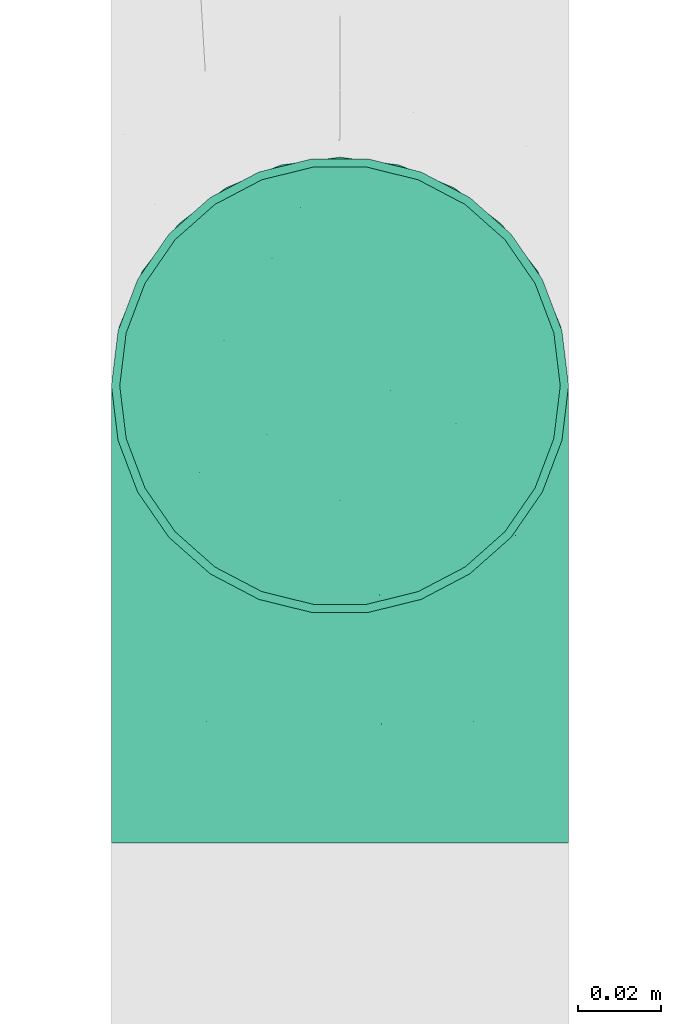
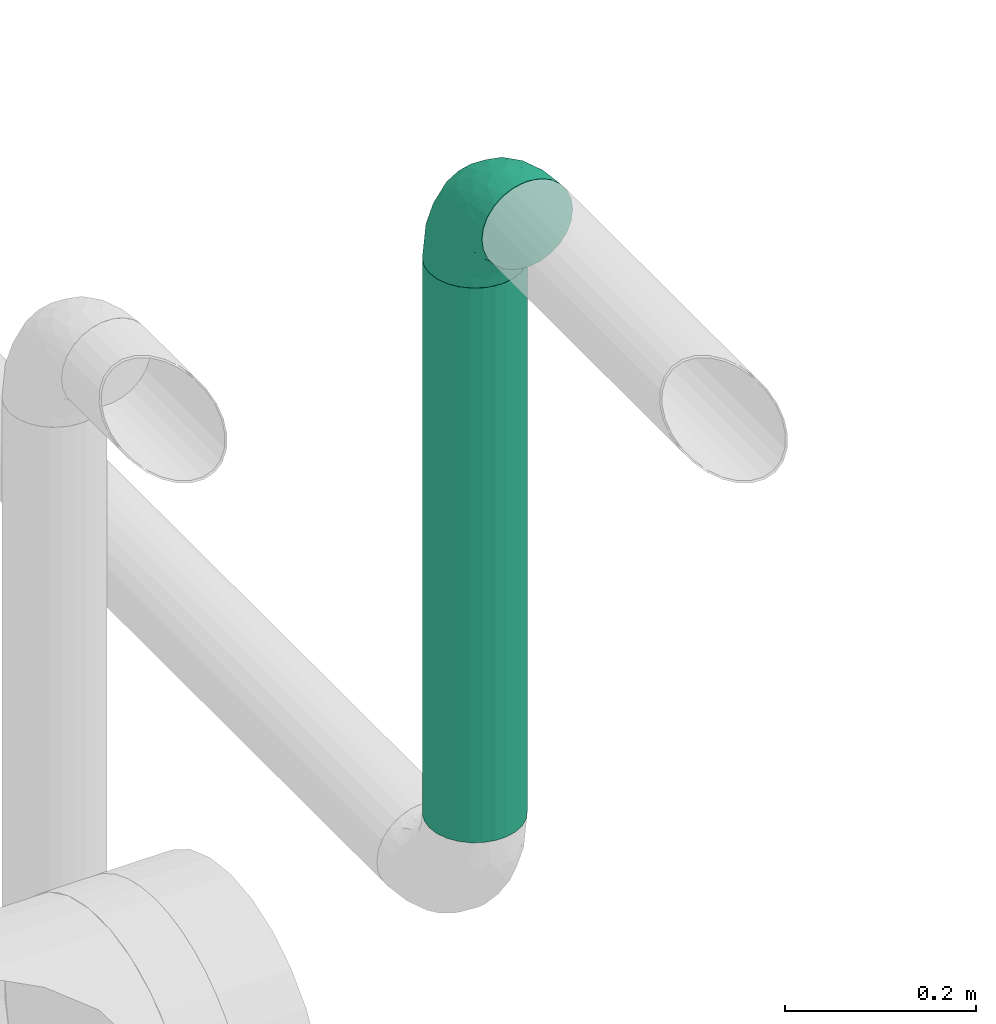
# One storey, part 77 of 91: 1 flow fitting, 1 flow segment.
"""IFC2X3 building model written with IfcOpenShell, lengths in millimetres."""

from ifc_helpers import new_model, entity, si_unit, converted_unit, derived_unit, direction, frame, origin_with_axes, origin_2d_with_axis, place, context, subcontext, project, spatial, hollow_circle, extrude, open_shell, surface_model, source, transform, mapped, material, layer, layer_set, layer_usage, type_object, element, save


model = new_model("IFC2X3")

# Units and contexts
model_context = context("Model", 3, precision=1e-05, world=origin_with_axes(), true_north=direction((0.0, 1.0)))
body_context = subcontext(model_context, "Body", "Model", "MODEL_VIEW")
ifc_project = project(units=[si_unit("AREAUNIT", "SQUARE_METRE"), si_unit("VOLUMEUNIT", "CUBIC_METRE", prefix="DECI"), si_unit("TIMEUNIT", "SECOND"), si_unit("THERMODYNAMICTEMPERATUREUNIT", "DEGREE_CELSIUS"), si_unit("PRESSUREUNIT", "PASCAL"), si_unit("MASSUNIT", "GRAM", prefix="KILO"), si_unit("LENGTHUNIT", "METRE", prefix="MILLI"), si_unit("POWERUNIT", "WATT"), si_unit("ELECTRICCURRENTUNIT", "AMPERE"), si_unit("ELECTRICVOLTAGEUNIT", "VOLT"), derived_unit("VOLUMETRICFLOWRATEUNIT", [(si_unit("VOLUMEUNIT", "CUBIC_METRE", prefix="DECI"), 1), (si_unit("TIMEUNIT", "SECOND"), -1)]), derived_unit("LINEARVELOCITYUNIT", [(si_unit("LENGTHUNIT", "METRE"), 1), (si_unit("TIMEUNIT", "SECOND"), -1)]), derived_unit("MASSDENSITYUNIT", [(si_unit("MASSUNIT", "GRAM", prefix="KILO"), 1), (si_unit("VOLUMEUNIT", "CUBIC_METRE"), -1)]), converted_unit("PLANEANGLEUNIT", "DEGREE", entity("IfcRatioMeasure", 0.01745), si_unit("PLANEANGLEUNIT", "RADIAN"), dimensions=[0, 0, 0, 0, 0, 0, 0])], contexts=[model_context])

# Site, building, storey
site_placement = place(None, origin_with_axes())
site = spatial("IfcSite", under=ifc_project, at=site_placement, CompositionType="ELEMENT")
building_placement = place(site_placement, origin_with_axes())
building = spatial("IfcBuilding", under=site, at=building_placement, Name="mc-building", CompositionType="ELEMENT")
storey_placement = place(building_placement, frame((0.0, 0.0, 8700.0), z_axis=(0.0, 0.0, 1.0), x_axis=(1.0, 0.0, 0.0)))
storey = spatial("IfcBuildingStorey", under=building, at=storey_placement, CompositionType="ELEMENT", Elevation=8700.0)

# Flow segment
ifc_material = material(Name="FZ1")
ifc_layer = layer(ifc_material, 0.0)
ifc_layer_set = layer_set([ifc_layer], Name="FZ1")
ifc_layer_usage = layer_usage(ifc_layer_set, "AXIS1", "POSITIVE", 0.0)
duct_segment_type = type_object("IfcDuctSegmentType", PredefinedType="RIGIDSEGMENT")
shared_shape_1 = source(origin_with_axes(), body_context, "Body", "SweptSolid", [
    extrude(hollow_circle(Radius=55.0, WallThickness=2.0, at=origin_2d_with_axis()), frame((0.0, 0.0, 0.0), z_axis=(1.0, 0.0, 0.0), x_axis=(0.0, 1.0, 0.0)), (0.0, 0.0, 1.0), 709.0),
])
flow_segment_placement = place(storey_placement, frame((26911.82755, 11040.50687, 1234.0), z_axis=(0.0, 1.0, 0.0), x_axis=(0.0, 0.0, -1.0)))
element("IfcFlowSegment", 1, at=flow_segment_placement, inside=storey, type_object=duct_segment_type, material=ifc_layer_usage, context=body_context, shape_type="MappedRepresentation", body=[
    mapped(shared_shape_1, transform((0.0, 0.0, 0.0), scale=1.0)),
])

# Flow fitting
duct_fitting_type = type_object("IfcDuctFittingType", Name="BU", PredefinedType="BEND")
shared_shape_2 = source(origin_with_axes(), body_context, "Body", "SurfaceModel", [
    surface_model("IfcShellBasedSurfaceModel", [(-110.0, 0.0, -55.0), (-110.0, -14.23505, -53.12592), (-110.0, 14.23505, -53.12592), (-110.0, 53.12592, 14.23505), (-110.0, 27.5, -47.63139), (-110.0, 38.89087, -38.89087), (-110.0, -55.0, 0.0), (-110.0, -53.12592, 14.23505), (-110.0, -38.89087, -38.89087), (-110.0, -27.5, -47.63139), (-110.0, -53.12592, -14.23505), (-110.0, -47.63139, -27.5), (-110.0, -14.23505, 53.12592), (-110.0, 14.23505, 53.12592), (-110.0, 27.5, 47.63139), (-110.0, -47.63139, 27.5), (-110.0, -38.89087, 38.89087), (-110.0, -27.5, 47.63139), (-110.0, 0.0, 55.0), (-110.0, 55.0, 0.0), (-110.0, 53.12592, -14.23505), (-110.0, 47.63139, -27.5), (-110.0, 47.63139, 27.5), (-110.0, 38.89087, 38.89087), (-14.23505, 110.0, -53.12592), (-55.0, 110.0, 0.0), (0.0, 110.0, -55.0), (-27.5, 110.0, -47.63139), (-38.89087, 110.0, -38.89087), (-47.63139, 110.0, -27.5), (38.89087, 110.0, -38.89087), (53.12592, 110.0, 14.23505), (27.5, 110.0, -47.63139), (14.23505, 110.0, -53.12592), (47.63139, 110.0, -27.5), (53.12592, 110.0, -14.23505), (55.0, 110.0, 0.0), (-53.12592, 110.0, -14.23505), (-53.12592, 110.0, 14.23505), (-47.63139, 110.0, 27.5), (-38.89087, 110.0, 38.89087), (-27.5, 110.0, 47.63139), (0.0, 110.0, 55.0), (-14.23505, 110.0, 53.12592), (38.89087, 110.0, 38.89087), (47.63139, 110.0, 27.5), (27.5, 110.0, 47.63139), (14.23505, 110.0, 53.12592), (-64.21732, 48.68956, 43.63444), (-76.6405, 38.18013, 45.55988), (-60.44912, 32.56953, 51.94617), (-76.00813, 5.38378, 55.0), (-90.15553, 11.94394, 54.09138), (-78.5998, 26.77405, 50.81338), (-70.18771, 18.55163, 54.03432), (-75.55424, 54.2118, 32.41257), (-93.27622, 45.77614, 33.48188), (-96.12334, 22.13664, 50.81337), (-21.00813, 45.34362, 55.0), (-18.36258, 70.48427, 54.04484), (-32.04182, 59.64019, 52.24446), (-63.88653, 74.77858, 17.99134), (-74.66383, 63.08407, 19.92123), (-63.60674, 66.07878, 29.97482), (-99.597, 52.72185, 18.52927), (-93.11138, 56.59448, 10.50359), (-98.21577, 57.34403, 0.0), (-53.42855, 92.60092, 21.04759), (-88.54852, 54.8376, 21.04759), (-11.86161, 90.23965, 54.10313), (-5.38378, 76.00813, 55.0), (-57.34403, 98.21577, 0.0), (-56.64619, 93.12774, 10.22088), (-45.34362, 21.00813, 55.0), (-44.60838, 44.60838, 52.13415), (-92.68484, 35.46673, 43.63443), (-22.25266, 95.40765, 50.81337), (-35.97783, 90.61597, 43.63443), (-43.70931, 69.58671, 44.47149), (-27.23711, 77.39884, 50.81337), (-57.2828, 79.3123, 24.9774), (-58.67786, 84.31125, 16.04456), (-82.93277, 60.36161, 12.91784), (-49.88337, 54.51816, 47.224), (-74.57753, 66.83759, 9.55742), (-45.35812, 94.97281, 33.48188), (-59.18663, 88.95241, 0.0), (-51.517, 78.6292, 33.48188), (-65.14788, 80.03077, 0.0), (-56.45322, 62.06476, 39.63545), (-88.95241, 59.18663, 0.0), (-71.10913, 71.10913, 0.0), (-80.03077, 65.14788, 0.0), (-94.9309, 45.36788, -33.48188), (-93.11358, 56.60141, -10.46614), (-99.64997, 52.79499, -18.30015), (-90.20425, 36.08686, -43.63443), (-79.99933, 46.56772, -37.92748), (-76.00813, 5.38378, -55.0), (-72.75364, 19.68651, -53.60527), (-45.34362, 21.00813, -55.0), (-21.91957, 65.12078, -53.85897), (-5.38378, 76.00813, -55.0), (-21.00813, 45.34362, -55.0), (-35.41876, 92.89265, -43.63443), (-91.10309, 11.02766, -54.21832), (-45.77614, 93.27622, -33.48188), (-90.50474, 23.21022, -50.81337), (-70.92854, 33.31794, -49.51754), (-78.52933, 63.35627, -11.73997), (-24.91508, 84.05606, -50.81337), (-88.78941, 54.74452, -21.04759), (-69.59921, 57.34866, -33.48187), (-73.36422, 62.46673, -22.94182), (-63.49062, 67.59111, -28.46929), (-56.59448, 93.11138, -10.50359), (-54.8376, 88.54852, -21.04759), (-54.10679, 75.85581, -32.31867), (-57.75956, 31.09612, -52.80882), (-52.72185, 99.597, -18.52927), (-12.62913, 89.46304, -53.99097), (-34.46825, 66.46123, -50.04329), (-43.9837, 43.9837, -52.42279), (-65.78527, 72.58348, -17.68796), (-70.34468, 43.65295, -44.21951), (-57.47001, 51.99467, -44.91465), (-60.72547, 82.29174, -12.88567), (-42.34915, 74.24548, -43.63444), (-57.25194, 63.5016, -38.08211), (-80.95344, 53.56991, -29.32027), (-52.32891, 4.55257, -54.0482), (32.52942, 47.13398, -30.48571), (14.88266, 20.92917, -33.7947), (14.95561, 36.05775, -42.26543), (30.24048, 70.09027, -41.7461), (19.3559, 65.35825, -48.00507), (-70.35075, -46.44478, -19.5952), (-47.13398, -32.52942, -30.48571), (-28.49299, -30.5778, -16.4009), (-4.55257, 52.32891, -54.0482), (-22.4954, 22.4954, -53.25347), (-75.47368, -11.22546, -52.60718), (-81.32209, -51.5606, -9.98467), (-80.81763, -41.84862, -32.14655), (-70.09027, -30.24048, -41.7461), (-36.05774, -14.95561, -42.26543), (-9.15831, -10.852, -27.8997), (-65.35825, -19.3559, -48.00507), (11.22546, 75.47368, -52.60718), (3.94376, 43.9333, -50.53315), (-13.39742, 13.39743, -48.13058), (-43.9333, -3.94376, -50.53315), (49.37776, 67.29486, 0.0), (41.8609, 47.82256, -9.92641), (50.20582, 74.51695, -9.9731), (18.93131, 11.7156, -17.56239), (-27.5, -32.89419, 0.0), (-1.23348, -12.25375, -12.18106), (41.84862, 80.81763, -32.14655), (35.70604, 41.31408, -20.38235), (46.44478, 70.35075, -19.5952), (32.89419, 27.5, 0.0), (6.67262, -6.67262, 0.0), (-67.29486, -49.37776, 0.0), (-50.36265, -42.95545, -9.51562), (-5.47251, 5.47251, -39.92906), (-70.35075, -46.44478, 19.5952), (-74.51695, -50.20582, 9.9731), (-41.31407, -35.70604, 20.38235), (-47.13398, -32.52942, 30.48571), (-80.81763, -41.84862, 32.14655), (-4.55257, 52.32891, 54.0482), (11.22546, 75.47368, 52.60718), (-43.9333, -3.94376, 50.53315), (-65.35825, -19.3559, 48.00507), (-36.05774, -14.95561, 42.26543), (-70.09027, -30.24048, 41.7461), (-11.7156, -18.93131, 17.56239), (30.5778, 28.49299, 16.4009), (12.25375, 1.23348, 12.18106), (51.5606, 81.32209, 9.98467), (42.95545, 50.36265, 9.51562), (-75.47368, -11.22546, 52.60718), (-52.32891, 4.55257, 54.0482), (3.94376, 43.9333, 50.53315), (-22.4954, 22.4954, 53.25347), (-13.39742, 13.39743, 48.13058), (10.852, 9.15831, 27.8997), (-20.92916, -14.88266, 33.79469), (-47.82256, -41.8609, 9.92641), (32.52942, 47.13398, 30.48571), (46.44478, 70.35075, 19.5952), (41.84862, 80.81763, 32.14655), (30.24048, 70.09027, 41.7461), (19.3559, 65.35825, 48.00507), (14.95561, 36.05775, 42.26543), (-5.47251, 5.47251, 39.92906)], [open_shell([[[0, 1, 2]], [[2, 3, 4]], [[4, 3, 5]], [[2, 6, 7]], [[8, 6, 9]], [[1, 9, 6]], [[10, 6, 11]], [[8, 11, 6]], [[6, 2, 1]], [[12, 13, 14]], [[15, 2, 7]], [[16, 17, 2]], [[2, 17, 12]], [[12, 18, 13]], [[19, 20, 3]], [[5, 3, 21]], [[20, 21, 3]], [[22, 3, 2]], [[23, 22, 2]], [[12, 14, 2]], [[2, 14, 23]], [[15, 16, 2]], [[24, 25, 26]], [[27, 25, 24]], [[25, 28, 29]], [[28, 25, 27]], [[30, 26, 31]], [[26, 30, 32]], [[32, 33, 26]], [[34, 31, 35]], [[31, 34, 30]], [[35, 31, 36]], [[29, 37, 25]], [[38, 39, 26]], [[39, 40, 26]], [[41, 42, 40]], [[42, 26, 40]], [[42, 41, 43]], [[26, 44, 45]], [[31, 26, 45]], [[26, 46, 44]], [[47, 46, 26]], [[42, 47, 26]], [[25, 38, 26]], [[48, 49, 50]], [[18, 51, 52]], [[53, 54, 50]], [[55, 56, 49]], [[56, 22, 23]], [[13, 57, 14]], [[58, 59, 60]], [[61, 62, 63]], [[3, 64, 65]], [[53, 52, 54]], [[3, 65, 66]], [[67, 39, 38]], [[56, 68, 64]], [[65, 64, 68]], [[69, 59, 70]], [[38, 71, 72]], [[73, 58, 74]], [[75, 49, 56]], [[76, 69, 43]], [[53, 57, 52]], [[77, 78, 79]], [[41, 76, 43]], [[43, 69, 42]], [[55, 68, 56]], [[23, 14, 75]], [[76, 77, 79]], [[80, 67, 81]], [[62, 82, 68]], [[60, 78, 83]], [[62, 84, 82]], [[85, 77, 40]], [[81, 67, 72]], [[86, 72, 71]], [[87, 85, 67]], [[61, 81, 88]], [[77, 41, 40]], [[78, 77, 87]], [[23, 75, 56]], [[83, 89, 48]], [[85, 40, 39]], [[62, 68, 55]], [[89, 87, 63]], [[83, 48, 50]], [[57, 75, 14]], [[49, 75, 53]], [[67, 85, 39]], [[87, 77, 85]], [[63, 62, 55]], [[89, 55, 48]], [[80, 63, 87]], [[66, 65, 90]], [[66, 19, 3]], [[84, 91, 92]], [[92, 90, 82]], [[65, 82, 90]], [[61, 84, 62]], [[92, 82, 84]], [[68, 82, 65]], [[3, 22, 64]], [[56, 64, 22]], [[38, 25, 71]], [[81, 72, 86]], [[38, 72, 67]], [[91, 61, 88]], [[80, 81, 61]], [[63, 80, 61]], [[67, 80, 87]], [[77, 76, 41]], [[79, 59, 69]], [[79, 69, 76]], [[42, 69, 70]], [[60, 59, 79]], [[58, 70, 59]], [[78, 60, 79]], [[58, 60, 74]], [[52, 57, 13]], [[75, 57, 53]], [[18, 52, 13]], [[52, 51, 54]], [[51, 73, 54]], [[50, 73, 74]], [[73, 50, 54]], [[50, 74, 83]], [[60, 83, 74]], [[89, 83, 78]], [[87, 89, 78]], [[55, 89, 63]], [[50, 49, 53]], [[55, 49, 48]], [[81, 86, 88]], [[91, 84, 61]], [[5, 21, 93]], [[90, 94, 66]], [[20, 94, 95]], [[96, 93, 97]], [[98, 99, 100]], [[96, 4, 5]], [[101, 102, 103]], [[28, 27, 104]], [[2, 105, 0]], [[104, 106, 28]], [[99, 105, 107]], [[108, 107, 96]], [[90, 109, 94]], [[107, 2, 4]], [[20, 66, 94]], [[27, 24, 110]], [[109, 111, 94]], [[112, 113, 114]], [[37, 115, 71]], [[116, 106, 117]], [[99, 118, 100]], [[116, 115, 119]], [[37, 119, 115]], [[24, 120, 110]], [[121, 110, 101]], [[119, 106, 116]], [[101, 110, 120]], [[122, 103, 100]], [[117, 123, 116]], [[124, 125, 108]], [[115, 116, 126]], [[106, 29, 28]], [[26, 102, 120]], [[127, 104, 110]], [[97, 124, 96]], [[125, 122, 118]], [[128, 127, 125]], [[96, 5, 93]], [[115, 126, 86]], [[117, 106, 127]], [[111, 113, 129]], [[95, 93, 21]], [[97, 129, 112]], [[110, 104, 27]], [[106, 104, 127]], [[96, 107, 4]], [[99, 107, 108]], [[99, 108, 118]], [[105, 99, 98]], [[112, 114, 128]], [[121, 125, 127]], [[20, 19, 66]], [[109, 90, 92]], [[94, 111, 95]], [[91, 123, 109]], [[129, 113, 112]], [[93, 95, 111]], [[21, 20, 95]], [[71, 115, 86]], [[71, 25, 37]], [[123, 91, 88]], [[126, 116, 123]], [[123, 88, 126]], [[86, 126, 88]], [[37, 29, 119]], [[106, 119, 29]], [[129, 93, 111]], [[124, 112, 125]], [[0, 105, 98]], [[107, 105, 2]], [[125, 118, 108]], [[100, 118, 122]], [[93, 129, 97]], [[113, 111, 109]], [[109, 123, 113]], [[114, 123, 117]], [[123, 114, 113]], [[128, 114, 117]], [[127, 128, 117]], [[112, 128, 125]], [[103, 122, 101]], [[110, 121, 127]], [[101, 122, 121]], [[125, 121, 122]], [[26, 120, 24]], [[101, 120, 102]], [[96, 124, 108]], [[92, 91, 109]], [[112, 124, 97]], [[100, 130, 98]], [[131, 132, 133]], [[32, 134, 135]], [[136, 137, 138]], [[139, 140, 103]], [[98, 141, 0]], [[142, 10, 136]], [[143, 144, 137]], [[6, 10, 142]], [[137, 145, 146]], [[144, 147, 145]], [[143, 136, 11]], [[11, 136, 10]], [[8, 143, 11]], [[148, 149, 139]], [[8, 9, 144]], [[9, 1, 147]], [[130, 141, 98]], [[103, 140, 100]], [[148, 135, 149]], [[150, 151, 140]], [[152, 153, 154]], [[130, 140, 151]], [[148, 26, 33]], [[147, 1, 141]], [[155, 146, 132]], [[156, 138, 157]], [[134, 30, 158]], [[150, 140, 149]], [[158, 30, 34]], [[30, 134, 32]], [[153, 159, 160]], [[131, 160, 159]], [[144, 145, 137]], [[36, 152, 154]], [[146, 138, 137]], [[155, 161, 162]], [[158, 160, 131]], [[133, 149, 135]], [[156, 163, 164]], [[163, 142, 164]], [[139, 103, 102]], [[153, 152, 161]], [[34, 35, 160]], [[162, 157, 155]], [[132, 165, 133]], [[157, 146, 155]], [[140, 130, 100]], [[141, 130, 151]], [[141, 151, 147]], [[141, 1, 0]], [[102, 26, 148]], [[140, 139, 149]], [[102, 148, 139]], [[135, 33, 32]], [[151, 150, 145]], [[9, 147, 144]], [[151, 145, 147]], [[145, 165, 146]], [[135, 148, 33]], [[133, 135, 134]], [[131, 133, 134]], [[133, 165, 150]], [[133, 150, 149]], [[145, 150, 165]], [[132, 131, 159]], [[146, 165, 132]], [[160, 158, 34]], [[134, 158, 131]], [[144, 143, 8]], [[136, 143, 137]], [[155, 153, 161]], [[154, 153, 160]], [[153, 155, 159]], [[132, 159, 155]], [[160, 35, 154]], [[36, 154, 35]], [[164, 136, 138]], [[6, 142, 163]], [[136, 164, 142]], [[156, 164, 138]], [[156, 157, 162]], [[146, 157, 138]], [[15, 7, 166]], [[6, 163, 167]], [[168, 169, 166]], [[166, 169, 170]], [[171, 172, 70]], [[173, 174, 175]], [[17, 176, 174]], [[177, 156, 162]], [[176, 16, 170]], [[170, 16, 15]], [[161, 178, 179]], [[152, 180, 181]], [[182, 173, 183]], [[18, 12, 182]], [[184, 185, 186]], [[183, 185, 73]], [[183, 73, 51]], [[177, 187, 188]], [[189, 168, 166]], [[187, 178, 190]], [[16, 176, 17]], [[161, 152, 181]], [[45, 191, 31]], [[45, 44, 192]], [[192, 191, 45]], [[180, 36, 31]], [[193, 194, 195]], [[46, 47, 194]], [[193, 195, 190]], [[193, 44, 46]], [[172, 42, 70]], [[185, 58, 73]], [[189, 163, 156]], [[163, 189, 167]], [[70, 58, 171]], [[184, 171, 185]], [[169, 188, 175]], [[180, 31, 191]], [[192, 193, 190]], [[191, 190, 178]], [[182, 174, 173]], [[194, 47, 172]], [[190, 195, 187]], [[186, 185, 173]], [[162, 179, 177]], [[188, 196, 175]], [[179, 187, 177]], [[185, 171, 58]], [[172, 171, 184]], [[172, 184, 194]], [[172, 47, 42]], [[51, 18, 182]], [[185, 183, 173]], [[51, 182, 183]], [[174, 12, 17]], [[184, 186, 195]], [[46, 194, 193]], [[184, 195, 194]], [[195, 196, 187]], [[174, 182, 12]], [[175, 174, 176]], [[169, 175, 176]], [[175, 196, 186]], [[175, 186, 173]], [[195, 186, 196]], [[188, 169, 168]], [[187, 196, 188]], [[166, 170, 15]], [[176, 170, 169]], [[193, 192, 44]], [[191, 192, 190]], [[177, 189, 156]], [[167, 189, 166]], [[189, 177, 168]], [[188, 168, 177]], [[166, 7, 167]], [[6, 167, 7]], [[181, 191, 178]], [[36, 180, 152]], [[191, 181, 180]], [[161, 181, 178]], [[161, 179, 162]], [[187, 179, 178]]])]),
])
flow_fitting_placement = place(storey_placement, frame((26911.82755, 11040.50687, 1344.0), z_axis=(1.0, 0.0, 0.0), x_axis=(0.0, 0.0, 1.0)))
element("IfcFlowFitting", 2, at=flow_fitting_placement, inside=storey, type_object=duct_fitting_type, Name="BU", context=body_context, shape_type="MappedRepresentation", body=[
    mapped(shared_shape_2, transform((0.0, 0.0, 0.0), scale=1.0)),
])

save(model, "model.ifc")
